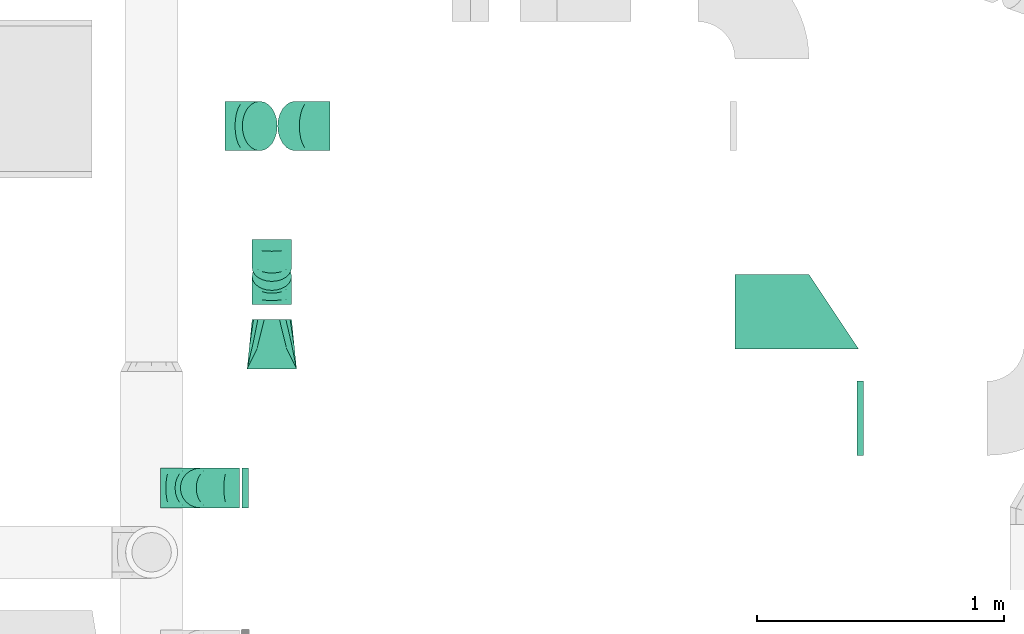
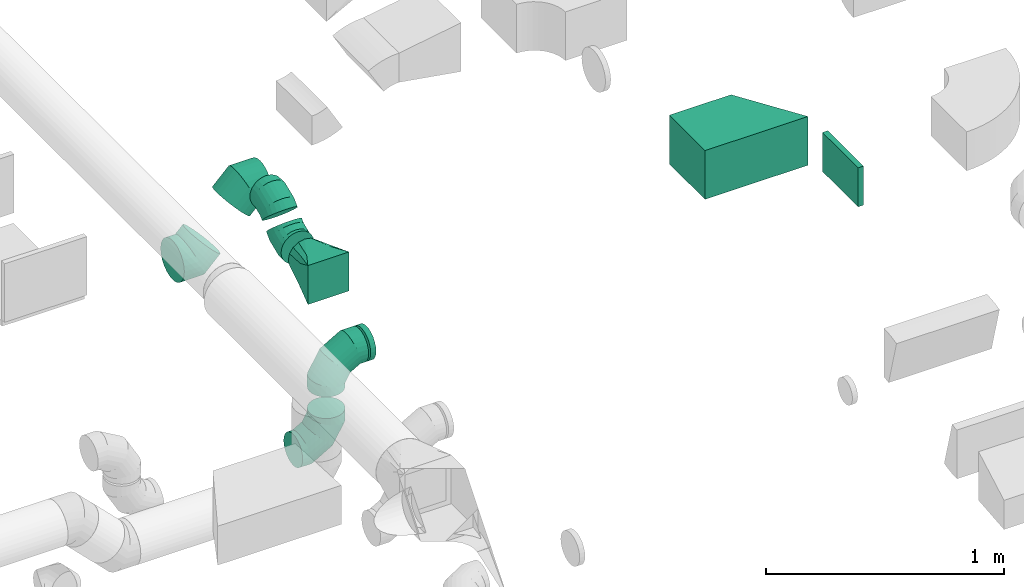
# One storey, part 45 of 62: 10 flow fittings.
"""IFC2X3 building model written with IfcOpenShell, lengths in millimetres."""

from ifc_helpers import new_model, entity, si_unit, converted_unit, derived_unit, direction, frame, origin, origin_2d_with_axis, place, context, subcontext, project, spatial, polyline, rectangle, outline, extrude, faceted_brep, source, transform, mapped, material, type_object, type_shapes, element, save


model = new_model("IFC2X3")

# Units and contexts
model_context = context("Model", 3, precision=0.01, world=origin(), true_north=direction((6.12303176911189e-17, 1.0)))
body_context = subcontext(model_context, "Body", "Model", "MODEL_VIEW")
ifc_project = project(units=[si_unit("LENGTHUNIT", "METRE", prefix="MILLI"), si_unit("AREAUNIT", "SQUARE_METRE"), si_unit("VOLUMEUNIT", "CUBIC_METRE"), converted_unit("PLANEANGLEUNIT", "DEGREE", entity("IfcRatioMeasure", 0.0174532925199433), si_unit("PLANEANGLEUNIT", "RADIAN"), dimensions=[0, 0, 0, 0, 0, 0, 0]), si_unit("MASSUNIT", "GRAM", prefix="KILO"), derived_unit("MASSDENSITYUNIT", [(si_unit("MASSUNIT", "GRAM", prefix="KILO"), 1), (si_unit("LENGTHUNIT", "METRE"), -3)]), derived_unit("MOMENTOFINERTIAUNIT", [(si_unit("LENGTHUNIT", "METRE"), 4)]), si_unit("TIMEUNIT", "SECOND"), si_unit("FREQUENCYUNIT", "HERTZ"), si_unit("THERMODYNAMICTEMPERATUREUNIT", "DEGREE_CELSIUS"), derived_unit("THERMALTRANSMITTANCEUNIT", [(si_unit("MASSUNIT", "GRAM", prefix="KILO"), 1), (si_unit("THERMODYNAMICTEMPERATUREUNIT", "KELVIN"), -1), (si_unit("TIMEUNIT", "SECOND"), -3)]), derived_unit("VOLUMETRICFLOWRATEUNIT", [(si_unit("LENGTHUNIT", "METRE"), 3), (si_unit("TIMEUNIT", "SECOND"), -1)]), derived_unit("MASSFLOWRATEUNIT", [(si_unit("MASSUNIT", "GRAM", prefix="KILO"), 1), (si_unit("TIMEUNIT", "SECOND"), -1)]), derived_unit("ROTATIONALFREQUENCYUNIT", [(si_unit("TIMEUNIT", "SECOND"), -1)]), si_unit("ELECTRICCURRENTUNIT", "AMPERE"), si_unit("ELECTRICVOLTAGEUNIT", "VOLT"), si_unit("POWERUNIT", "WATT"), si_unit("FORCEUNIT", "NEWTON", prefix="KILO"), si_unit("ILLUMINANCEUNIT", "LUX"), si_unit("LUMINOUSFLUXUNIT", "LUMEN"), si_unit("LUMINOUSINTENSITYUNIT", "CANDELA"), derived_unit("USERDEFINED", [(si_unit("MASSUNIT", "GRAM", prefix="KILO"), -1), (si_unit("LENGTHUNIT", "METRE"), -2), (si_unit("TIMEUNIT", "SECOND"), 3), (si_unit("LUMINOUSFLUXUNIT", "LUMEN"), 1)]), derived_unit("LINEARVELOCITYUNIT", [(si_unit("LENGTHUNIT", "METRE"), 1), (si_unit("TIMEUNIT", "SECOND"), -1)]), si_unit("PRESSUREUNIT", "PASCAL"), derived_unit("USERDEFINED", [(si_unit("LENGTHUNIT", "METRE"), -2), (si_unit("MASSUNIT", "GRAM", prefix="KILO"), 1), (si_unit("TIMEUNIT", "SECOND"), -2)]), derived_unit("LINEARFORCEUNIT", [(si_unit("MASSUNIT", "GRAM", prefix="KILO"), 1), (si_unit("LENGTHUNIT", "METRE"), 1), (si_unit("TIMEUNIT", "SECOND"), -2), (si_unit("LENGTHUNIT", "METRE"), -1)]), derived_unit("PLANARFORCEUNIT", [(si_unit("MASSUNIT", "GRAM", prefix="KILO"), 1), (si_unit("LENGTHUNIT", "METRE"), 1), (si_unit("TIMEUNIT", "SECOND"), -2), (si_unit("LENGTHUNIT", "METRE"), -2)])], contexts=[model_context])

# Site, building, storey
site_placement = place(None, origin())
site = spatial("IfcSite", under=ifc_project, at=site_placement, CompositionType="ELEMENT")
building_placement = place(site_placement, origin())
building = spatial("IfcBuilding", under=site, at=building_placement, CompositionType="ELEMENT")
storey_placement = place(building_placement, frame((0.0, 0.0, 24000.0)))
storey = spatial("IfcBuildingStorey", under=building, at=storey_placement, CompositionType="ELEMENT", Elevation=24000.0)

# Flow fittings
ifc_material = material()
duct_fitting_type_1 = type_object("IfcDuctFittingType", PredefinedType="NOTDEFINED", material=ifc_material)
shared_shape_1 = source(origin(), body_context, "Body", "SweptSolid", [
    extrude(rectangle(XDim=26.096000000001, YDim=300.0, at=origin_2d_with_axis()), frame((6.95, 0.0, -100.0)), (0.0, 0.0, 1.0), 200.0),
])
type_shapes(duct_fitting_type_1, [shared_shape_1])
flow_fitting_1_placement = place(storey_placement, frame((53615.82, 12852.02, 3400.0), z_axis=(0.0, 0.0, -1.0), x_axis=(1.0, 0.0, 0.0)))
element("IfcFlowFitting", 1, at=flow_fitting_1_placement, inside=storey, type_object=duct_fitting_type_1, material=ifc_material, context=body_context, shape_type="MappedRepresentation", body=[
    mapped(shared_shape_1, transform((0.0, 0.0, 0.0), scale=1.0)),
])
duct_fitting_type_2 = type_object("IfcDuctFittingType", PredefinedType="NOTDEFINED", material=ifc_material)
shared_shape_2 = source(origin(), body_context, "Body", "SweptSolid", [
    extrude(outline(polyline([(-291.22, -166.41), (69.34, -166.41), (235.75, 83.21), (-13.87, 249.62), (-291.22, -166.41)])), frame((150.0, 50.0, -125.0), z_axis=(0.0, 0.0, 1.0), x_axis=(0.832050294337984, 0.554700196225018, 0.0)), (0.0, 0.0, 1.0), 250.0),
])
type_shapes(duct_fitting_type_2, [shared_shape_2])
flow_fitting_2_placement = place(storey_placement, frame((53365.82, 13133.04, 3375.0), z_axis=(0.0, 0.0, 1.0), x_axis=(0.0, 1.0, 0.0)))
element("IfcFlowFitting", 2, at=flow_fitting_2_placement, inside=storey, type_object=duct_fitting_type_2, material=ifc_material, context=body_context, shape_type="MappedRepresentation", body=[
    mapped(shared_shape_2, transform((0.0, 0.0, 0.0), scale=1.0)),
])
duct_fitting_type_3 = type_object("IfcDuctFittingType", PredefinedType="NOTDEFINED", material=ifc_material)
shared_shape_3 = source(origin(), body_context, "Body", "Brep", [
    faceted_brep([(-160.0, 0.0, -80.0), (-160.0, -20.71, -77.27), (-160.0, -40.0, -69.28), (-160.0, -56.57, -56.57), (-160.0, -69.28, -40.0), (-160.0, -77.27, -20.71), (-160.0, -80.0, 0.0), (-160.0, -77.27, 20.71), (-160.0, -69.28, 40.0), (-160.0, -56.57, 56.57), (-160.0, -40.0, 69.28), (-160.0, -20.71, 77.27), (-160.0, 0.0, 80.0), (-160.0, 20.71, 77.27), (-160.0, 40.0, 69.28), (-160.0, 56.57, 56.57), (-160.0, 69.28, 40.0), (-160.0, 77.27, 20.71), (-160.0, 80.0, 0.0), (-160.0, 77.27, -20.71), (-160.0, 69.28, -40.0), (-160.0, 56.57, -56.57), (-160.0, 40.0, -69.28), (-160.0, 20.71, -77.27), (-122.68, 20.71, 77.27), (-127.85, 40.0, 69.28), (-117.13, 0.0, 80.0), (-132.29, 56.57, 56.57), (-137.83, 77.27, 20.71), (-138.56, 80.0, 0.0), (-135.69, 69.28, 40.0), (-135.69, 69.28, -40.0), (-132.29, 56.57, -56.57), (-137.83, 77.27, -20.71), (-122.68, 20.71, -77.27), (-117.13, 0.0, -80.0), (-127.85, 40.0, -69.28), (-111.58, -20.71, -77.27), (-106.41, -40.0, -69.28), (-101.97, -56.57, -56.57), (-98.56, -69.28, -40.0), (-96.42, -77.27, -20.71), (-95.69, -80.0, 0.0), (-96.42, -77.27, 20.71), (-98.56, -69.28, 40.0), (-101.97, -56.57, 56.57), (-106.41, -40.0, 69.28), (-111.58, -20.71, 77.27), (-58.03, 58.03, 77.27), (-72.15, 72.15, 69.28), (-42.87, 42.87, 80.0), (-84.28, 84.28, 56.57), (-93.59, 93.59, 40.0), (-99.44, 99.44, 20.71), (-101.44, 101.44, 0.0), (-99.44, 99.44, -20.71), (-93.59, 93.59, -40.0), (-84.28, 84.28, -56.57), (-58.03, 58.03, -77.27), (-42.87, 42.87, -80.0), (-72.15, 72.15, -69.28), (-27.71, 27.71, -77.27), (-13.59, 13.59, -69.28), (-1.46, 1.46, -56.57), (7.85, -7.85, -40.0), (13.7, -13.7, -20.71), (15.69, -15.69, 0.0), (13.7, -13.7, 20.71), (7.85, -7.85, 40.0), (-1.46, 1.46, 56.57), (-13.59, 13.59, 69.28), (-27.71, 27.71, 77.27), (-20.71, 122.68, 77.27), (-40.0, 127.85, 69.28), (0.0, 117.13, 80.0), (-56.57, 132.29, 56.57), (-69.28, 135.69, 40.0), (-77.27, 137.83, 20.71), (-80.0, 138.56, 0.0), (-77.27, 137.83, -20.71), (-69.28, 135.69, -40.0), (-56.57, 132.29, -56.57), (-20.71, 122.68, -77.27), (0.0, 117.13, -80.0), (-40.0, 127.85, -69.28), (20.71, 111.58, -77.27), (40.0, 106.41, -69.28), (56.57, 101.97, -56.57), (69.28, 98.56, -40.0), (77.27, 96.42, -20.71), (80.0, 95.69, 0.0), (77.27, 96.42, 20.71), (69.28, 98.56, 40.0), (56.57, 101.97, 56.57), (40.0, 106.41, 69.28), (20.71, 111.58, 77.27), (-20.71, 160.0, -77.27), (-40.0, 160.0, -69.28), (-56.57, 160.0, -56.57), (-69.28, 160.0, -40.0), (-77.27, 160.0, -20.71), (-80.0, 160.0, 0.0), (-77.27, 160.0, 20.71), (-69.28, 160.0, 40.0), (-56.57, 160.0, 56.57), (-40.0, 160.0, 69.28), (-20.71, 160.0, 77.27), (0.0, 160.0, 80.0), (20.71, 160.0, 77.27), (40.0, 160.0, 69.28), (56.57, 160.0, 56.57), (69.28, 160.0, 40.0), (77.27, 160.0, 20.71), (80.0, 160.0, 0.0), (77.27, 160.0, -20.71), (69.28, 160.0, -40.0), (56.57, 160.0, -56.57), (40.0, 160.0, -69.28), (20.71, 160.0, -77.27), (0.0, 160.0, -80.0)], [[[0, 1, 2, 3, 4, 5, 6, 7, 8, 9, 10, 11, 12, 13, 14, 15, 16, 17, 18, 19, 20, 21, 22, 23]], [[24, 25, 14, 13]], [[26, 24, 13, 12]], [[14, 25, 27, 15]], [[28, 29, 18, 17]], [[30, 28, 17, 16]], [[15, 27, 30, 16]], [[20, 31, 32, 21]], [[33, 31, 20, 19]], [[18, 29, 33, 19]], [[34, 35, 0, 23]], [[36, 34, 23, 22]], [[32, 36, 22, 21]], [[1, 0, 35, 37]], [[2, 1, 37, 38]], [[3, 2, 38, 39]], [[5, 4, 40, 41]], [[6, 5, 41, 42]], [[39, 40, 4, 3]], [[6, 42, 43, 7]], [[7, 43, 44, 8]], [[8, 44, 45, 9]], [[9, 45, 46, 10]], [[10, 46, 47, 11]], [[26, 12, 11, 47]], [[48, 49, 25, 24]], [[50, 48, 24, 26]], [[27, 25, 49, 51]], [[52, 53, 28, 30]], [[51, 52, 30, 27]], [[29, 28, 53, 54]], [[55, 56, 31, 33]], [[54, 55, 33, 29]], [[32, 31, 56, 57]], [[58, 59, 35, 34]], [[60, 58, 34, 36]], [[57, 60, 36, 32]], [[37, 35, 59, 61]], [[38, 37, 61, 62]], [[39, 38, 62, 63]], [[41, 40, 64, 65]], [[42, 41, 65, 66]], [[63, 64, 40, 39]], [[43, 42, 66, 67]], [[44, 43, 67, 68]], [[68, 69, 45, 44]], [[46, 45, 69, 70]], [[47, 46, 70, 71]], [[26, 47, 71, 50]], [[72, 73, 49, 48]], [[74, 72, 48, 50]], [[51, 49, 73, 75]], [[76, 77, 53, 52]], [[75, 76, 52, 51]], [[54, 53, 77, 78]], [[79, 80, 56, 55]], [[78, 79, 55, 54]], [[57, 56, 80, 81]], [[82, 83, 59, 58]], [[84, 82, 58, 60]], [[81, 84, 60, 57]], [[61, 59, 83, 85]], [[62, 61, 85, 86]], [[63, 62, 86, 87]], [[65, 64, 88, 89]], [[66, 65, 89, 90]], [[87, 88, 64, 63]], [[67, 66, 90, 91]], [[68, 67, 91, 92]], [[92, 93, 69, 68]], [[70, 69, 93, 94]], [[71, 70, 94, 95]], [[50, 71, 95, 74]], [[96, 97, 98, 99, 100, 101, 102, 103, 104, 105, 106, 107, 108, 109, 110, 111, 112, 113, 114, 115, 116, 117, 118, 119]], [[72, 74, 107, 106]], [[73, 72, 106, 105]], [[75, 73, 105, 104]], [[77, 76, 103, 102]], [[78, 77, 102, 101]], [[75, 104, 103, 76]], [[78, 101, 100, 79]], [[79, 100, 99, 80]], [[80, 99, 98, 81]], [[84, 97, 96, 82]], [[82, 96, 119, 83]], [[84, 81, 98, 97]], [[118, 117, 86, 85]], [[119, 118, 85, 83]], [[116, 87, 86, 117]], [[88, 115, 114, 89]], [[89, 114, 113, 90]], [[115, 88, 87, 116]], [[112, 111, 92, 91]], [[113, 112, 91, 90]], [[111, 110, 93, 92]], [[95, 94, 109, 108]], [[74, 95, 108, 107]], [[110, 109, 94, 93]]]),
])
type_shapes(duct_fitting_type_3, [shared_shape_3])
for number, where, z_axis, x_axis in (
    (3, (50952.88, 12570.09, 3120.0), (0.0, -1.0, 0.0), (1.0, 0.0, 0.0)),
    (4, (50952.88, 12570.09, 3550.0), (0.0, 1.0, 0.0), (0.0, 0.0, 1.0)),
):
    element("IfcFlowFitting", number, at=place(storey_placement, frame(where, z_axis=z_axis, x_axis=x_axis)), inside=storey, type_object=duct_fitting_type_3, material=ifc_material, context=body_context, shape_type="MappedRepresentation", body=[
        mapped(shared_shape_3, transform((0.0, 0.0, 0.0), scale=1.0)),
    ])
duct_fitting_type_4 = type_object("IfcDuctFittingType", PredefinedType="NOTDEFINED", material=ifc_material)
shared_shape_4 = source(origin(), body_context, "Body", "Brep", [
    faceted_brep([(-82.84, 0.0, -100.0), (-82.84, -25.88, -96.59), (-82.84, -50.0, -86.6), (-82.84, -70.71, -70.71), (-82.84, -86.6, -50.0), (-82.84, -96.59, -25.88), (-82.84, -100.0, 0.0), (-82.84, -96.59, 25.88), (-82.84, -86.6, 50.0), (-82.84, -70.71, 70.71), (-82.84, -50.0, 86.6), (-82.84, -25.88, 96.59), (-82.84, 0.0, 100.0), (-82.84, 25.88, 96.59), (-82.84, 50.0, 86.6), (-82.84, 70.71, 70.71), (-82.84, 86.6, 50.0), (-82.84, 96.59, 25.88), (-82.84, 100.0, 0.0), (-82.84, 96.59, -25.88), (-82.84, 86.6, -50.0), (-82.84, 70.71, -70.71), (-82.84, 50.0, -86.6), (-82.84, 25.88, -96.59), (-10.72, 25.88, 96.59), (-20.71, 50.0, 86.6), (0.0, 0.0, 100.0), (-29.29, 70.71, 70.71), (-35.87, 86.6, 50.0), (-40.01, 96.59, 25.88), (-41.42, 100.0, 0.0), (-40.01, 96.59, -25.88), (-35.87, 86.6, -50.0), (-29.29, 70.71, -70.71), (-10.72, 25.88, -96.59), (0.0, 0.0, -100.0), (-20.71, 50.0, -86.6), (10.72, -25.88, -96.59), (20.71, -50.0, -86.6), (29.29, -70.71, -70.71), (35.87, -86.6, -50.0), (40.01, -96.59, -25.88), (41.42, -100.0, 0.0), (40.01, -96.59, 25.88), (35.87, -86.6, 50.0), (29.29, -70.71, 70.71), (20.71, -50.0, 86.6), (10.72, -25.88, 96.59), (58.58, 58.58, 100.0), (40.28, 76.88, 96.59), (23.22, 93.93, 86.6), (8.58, 108.58, 70.71), (-2.66, 119.82, 50.0), (-9.72, 126.88, 25.88), (-12.13, 129.29, 0.0), (-9.72, 126.88, -25.88), (-2.66, 119.82, -50.0), (8.58, 108.58, -70.71), (23.22, 93.93, -86.6), (40.28, 76.88, -96.59), (58.58, 58.58, -100.0), (76.88, 40.28, -96.59), (93.93, 23.22, -86.6), (108.58, 8.58, -70.71), (119.82, -2.66, -50.0), (126.88, -9.72, -25.88), (129.29, -12.13, 0.0), (126.88, -9.72, 25.88), (119.82, -2.66, 50.0), (108.58, 8.58, 70.71), (93.93, 23.22, 86.6), (76.88, 40.28, 96.59)], [[[0, 1, 2, 3, 4, 5, 6, 7, 8, 9, 10, 11, 12, 13, 14, 15, 16, 17, 18, 19, 20, 21, 22, 23]], [[24, 25, 14, 13]], [[26, 24, 13, 12]], [[14, 25, 27, 15]], [[28, 29, 17, 16]], [[28, 16, 15, 27]], [[30, 18, 17, 29]], [[31, 32, 20, 19]], [[30, 31, 19, 18]], [[32, 33, 21, 20]], [[34, 35, 0, 23]], [[36, 34, 23, 22]], [[33, 36, 22, 21]], [[1, 0, 35, 37]], [[2, 1, 37, 38]], [[38, 39, 3, 2]], [[5, 4, 40, 41]], [[6, 5, 41, 42]], [[39, 40, 4, 3]], [[6, 42, 43, 7]], [[7, 43, 44, 8]], [[8, 44, 45, 9]], [[9, 45, 46, 10]], [[10, 46, 47, 11]], [[26, 12, 11, 47]], [[24, 26, 48, 49]], [[25, 24, 49, 50]], [[27, 25, 50, 51]], [[29, 28, 52, 53]], [[30, 29, 53, 54]], [[51, 52, 28, 27]], [[30, 54, 55, 31]], [[31, 55, 56, 32]], [[57, 33, 32, 56]], [[36, 58, 59, 34]], [[34, 59, 60, 35]], [[58, 36, 33, 57]], [[35, 60, 61, 37]], [[37, 61, 62, 38]], [[63, 39, 38, 62]], [[40, 64, 65, 41]], [[41, 65, 66, 42]], [[64, 40, 39, 63]], [[43, 42, 66, 67]], [[44, 43, 67, 68]], [[68, 69, 45, 44]], [[47, 46, 70, 71]], [[26, 47, 71, 48]], [[69, 70, 46, 45]], [[59, 58, 57, 56, 55, 54, 53, 52, 51, 50, 49, 48, 71, 70, 69, 68, 67, 66, 65, 64, 63, 62, 61, 60]]]),
])
type_shapes(duct_fitting_type_4, [shared_shape_4])
for number, where, z_axis, x_axis in (
    (5, (51395.82, 14034.27, 3375.0), (0.0, -1.0, 0.0), (-1.0, 0.0, 0.0)),
    (6, (51135.53, 14034.27, 3114.71), (0.0, 1.0, 0.0), (-0.707106781186499, 0.0, -0.707106781186596)),
):
    element("IfcFlowFitting", number, at=place(storey_placement, frame(where, z_axis=z_axis, x_axis=x_axis)), inside=storey, type_object=duct_fitting_type_4, material=ifc_material, context=body_context, shape_type="MappedRepresentation", body=[
        mapped(shared_shape_4, transform((0.0, 0.0, 0.0), scale=1.0)),
    ])
duct_fitting_type_5 = type_object("IfcDuctFittingType", PredefinedType="NOTDEFINED", material=ifc_material)
shared_shape_5 = source(origin(), body_context, "Body", "Brep", [
    faceted_brep([(20.0, 20.71, -77.27), (20.0, 40.0, -69.28), (20.0, 56.57, -56.57), (20.0, 69.28, -40.0), (20.0, 77.27, -20.71), (20.0, 80.0, 0.0), (20.0, 77.27, 20.71), (20.0, 69.28, 40.0), (20.0, 56.57, 56.57), (20.0, 40.0, 69.28), (20.0, 20.71, 77.27), (20.0, 0.0, 80.0), (20.0, -20.71, 77.27), (20.0, -40.0, 69.28), (20.0, -56.57, 56.57), (20.0, -69.28, 40.0), (20.0, -77.27, 20.71), (20.0, -80.0, 0.0), (20.0, -77.27, -20.71), (20.0, -69.28, -40.0), (20.0, -56.57, -56.57), (20.0, -40.0, -69.28), (20.0, -20.71, -77.27), (20.0, 0.0, -80.0), (0.0, 0.0, 80.0), (0.0, 20.71, 77.27), (-6.1, 20.71, 77.27), (-6.1, 0.0, 80.0), (0.0, 40.0, 69.28), (-6.1, 40.0, 69.28), (0.0, 56.57, 56.57), (-6.1, 56.57, 56.57), (0.0, 69.28, 40.0), (0.0, 77.27, 20.71), (-6.1, 77.27, 20.71), (-6.1, 69.28, 40.0), (0.0, 80.0, 0.0), (-6.1, 80.0, 0.0), (0.0, 77.27, -20.71), (-6.1, 77.27, -20.71), (0.0, 69.28, -40.0), (-6.1, 69.28, -40.0), (0.0, 56.57, -56.57), (-6.1, 56.57, -56.57), (0.0, 40.0, -69.28), (0.0, 20.71, -77.27), (-6.1, 20.71, -77.27), (-6.1, 40.0, -69.28), (0.0, 0.0, -80.0), (-6.1, 0.0, -80.0), (0.0, -20.71, -77.27), (-6.1, -20.71, -77.27), (0.0, -40.0, -69.28), (-6.1, -40.0, -69.28), (0.0, -56.57, -56.57), (-6.1, -56.57, -56.57), (0.0, -69.28, -40.0), (0.0, -77.27, -20.71), (-6.1, -77.27, -20.71), (-6.1, -69.28, -40.0), (0.0, -80.0, 0.0), (-6.1, -80.0, 0.0), (0.0, -77.27, 20.71), (-6.1, -77.27, 20.71), (0.0, -69.28, 40.0), (-6.1, -69.28, 40.0), (0.0, -56.57, 56.57), (-6.1, -56.57, 56.57), (0.0, -40.0, 69.28), (0.0, -20.71, 77.27), (-6.1, -20.71, 77.27), (-6.1, -40.0, 69.28)], [[[0, 1, 2, 3, 4, 5, 6, 7, 8, 9, 10, 11, 12, 13, 14, 15, 16, 17, 18, 19, 20, 21, 22, 23]], [[24, 11, 10, 25, 26, 27]], [[25, 10, 9, 28, 29, 26]], [[28, 9, 8, 30, 31, 29]], [[32, 7, 6, 33, 34, 35]], [[33, 6, 5, 36, 37, 34]], [[30, 8, 7, 32, 35, 31]], [[36, 5, 4, 38, 39, 37]], [[38, 4, 3, 40, 41, 39]], [[40, 3, 2, 42, 43, 41]], [[44, 1, 0, 45, 46, 47]], [[45, 0, 23, 48, 49, 46]], [[42, 2, 1, 44, 47, 43]], [[48, 23, 22, 50, 51, 49]], [[50, 22, 21, 52, 53, 51]], [[52, 21, 20, 54, 55, 53]], [[56, 19, 18, 57, 58, 59]], [[57, 18, 17, 60, 61, 58]], [[54, 20, 19, 56, 59, 55]], [[60, 17, 16, 62, 63, 61]], [[62, 16, 15, 64, 65, 63]], [[64, 15, 14, 66, 67, 65]], [[68, 13, 12, 69, 70, 71]], [[69, 12, 11, 24, 27, 70]], [[66, 14, 13, 68, 71, 67]], [[49, 51, 53, 55, 59, 58, 61, 63, 65, 67, 71, 70, 27, 26, 29, 31, 35, 34, 37, 39, 41, 43, 47, 46]]]),
])
type_shapes(duct_fitting_type_5, [shared_shape_5])
flow_fitting_3_placement = place(storey_placement, frame((51142.9, 12570.09, 3550.0), z_axis=(0.0, 0.0, -1.0), x_axis=(-1.0, 0.0, 0.0)))
element("IfcFlowFitting", 7, at=flow_fitting_3_placement, inside=storey, type_object=duct_fitting_type_5, material=ifc_material, context=body_context, shape_type="MappedRepresentation", body=[
    mapped(shared_shape_5, transform((0.0, 0.0, 0.0), scale=1.0)),
])
duct_fitting_type_6 = type_object("IfcDuctFittingType", PredefinedType="NOTDEFINED", material=ifc_material)
shared_shape_6 = source(origin(), body_context, "Body", "Brep", [
    faceted_brep([(200.0, 30.61, 73.91), (200.0, 22.87, 75.45), (200.0, 15.12, 76.99), (200.0, 11.34, 77.74), (200.0, 7.56, 78.5), (200.0, 0.0, 80.0), (200.0, -7.56, 78.5), (200.0, -15.12, 76.99), (200.0, -18.99, 76.22), (200.0, -22.87, 75.45), (200.0, -30.61, 73.91), (200.0, -37.1, 69.57), (200.0, -43.59, 65.24), (200.0, -50.08, 60.9), (200.0, -56.57, 56.57), (200.0, -60.9, 50.08), (200.0, -65.24, 43.59), (200.0, -69.57, 37.1), (200.0, -73.91, 30.61), (200.0, -75.45, 22.87), (200.0, -76.99, 15.12), (200.0, -77.74, 11.34), (200.0, -78.5, 7.56), (200.0, -80.0, 0.0), (200.0, -78.5, -7.56), (200.0, -76.99, -15.12), (200.0, -76.22, -18.99), (200.0, -75.45, -22.87), (200.0, -73.91, -30.61), (200.0, -69.57, -37.1), (200.0, -65.24, -43.59), (200.0, -60.9, -50.08), (200.0, -56.57, -56.57), (200.0, -50.08, -60.9), (200.0, -43.59, -65.24), (200.0, -37.1, -69.57), (200.0, -30.61, -73.91), (200.0, -22.87, -75.45), (200.0, -15.12, -76.99), (200.0, -11.34, -77.74), (200.0, -7.56, -78.5), (200.0, 0.0, -80.0), (200.0, 7.56, -78.5), (200.0, 15.12, -76.99), (200.0, 18.99, -76.22), (200.0, 22.87, -75.45), (200.0, 30.61, -73.91), (200.0, 37.1, -69.57), (200.0, 43.59, -65.24), (200.0, 50.08, -60.9), (200.0, 56.57, -56.57), (200.0, 60.9, -50.08), (200.0, 65.24, -43.59), (200.0, 69.57, -37.1), (200.0, 73.91, -30.61), (200.0, 75.45, -22.87), (200.0, 76.99, -15.12), (200.0, 77.74, -11.34), (200.0, 78.5, -7.56), (200.0, 80.0, 0.0), (200.0, 78.5, 7.56), (200.0, 76.99, 15.12), (200.0, 76.22, 18.99), (200.0, 75.45, 22.87), (200.0, 73.91, 30.61), (200.0, 69.57, 37.1), (200.0, 65.24, 43.59), (200.0, 60.9, 50.08), (200.0, 56.57, 56.57), (200.0, 50.08, 60.9), (200.0, 43.59, 65.24), (200.0, 37.1, 69.57), (0.0, -100.0, 100.0), (0.0, 100.0, 100.0), (0.0, 100.0, -100.0), (0.0, -100.0, -100.0), (52.06, -73.97, 94.79), (78.09, -60.96, 92.19), (176.03, -11.99, 82.4), (152.06, -23.97, 84.79), (128.09, -35.96, 87.19), (104.11, -47.94, 89.59), (100.0, -79.94, 76.52), (78.09, -92.19, 60.96), (104.11, -89.59, 47.94), (128.09, -87.19, 35.96), (152.06, -84.79, 23.97), (164.04, -83.6, 17.98), (176.03, -82.4, 11.99), (26.03, -97.4, 86.99), (52.06, -94.79, 73.97), (26.03, -86.99, 97.4), (26.03, -97.4, -86.99), (52.06, -94.79, -73.97), (78.09, -92.19, -60.96), (104.11, -89.59, -47.94), (128.09, -87.19, -35.96), (152.06, -84.79, -23.97), (176.03, -82.4, -11.99), (100.0, -76.52, -79.94), (78.09, -60.96, -92.19), (104.11, -47.94, -89.59), (128.09, -35.96, -87.19), (152.06, -23.97, -84.79), (164.04, -17.98, -83.6), (176.03, -11.99, -82.4), (26.03, -86.99, -97.4), (52.06, -73.97, -94.79), (26.03, 86.99, -97.4), (52.06, 73.97, -94.79), (78.09, 60.96, -92.19), (104.11, 47.94, -89.59), (128.09, 35.96, -87.19), (152.06, 23.97, -84.79), (176.03, 11.99, -82.4), (100.0, 79.94, -76.52), (78.09, 92.19, -60.96), (104.11, 89.59, -47.94), (128.09, 87.19, -35.96), (152.06, 84.79, -23.97), (164.04, 83.6, -17.98), (176.03, 82.4, -11.99), (26.03, 97.4, -86.99), (52.06, 94.79, -73.97), (26.03, 97.4, 86.99), (52.06, 94.79, 73.97), (78.09, 92.19, 60.96), (104.11, 89.59, 47.94), (128.09, 87.19, 35.96), (152.06, 84.79, 23.97), (176.03, 82.4, 11.99), (100.0, 76.52, 79.94), (78.09, 60.96, 92.19), (104.11, 47.94, 89.59), (128.09, 35.96, 87.19), (152.06, 23.97, 84.79), (164.04, 17.98, 83.6), (176.03, 11.99, 82.4), (26.03, 86.99, 97.4), (52.06, 73.97, 94.79)], [[[0, 1, 2, 3, 4, 5, 6, 7, 8, 9, 10, 11, 12, 13, 14, 15, 16, 17, 18, 19, 20, 21, 22, 23, 24, 25, 26, 27, 28, 29, 30, 31, 32, 33, 34, 35, 36, 37, 38, 39, 40, 41, 42, 43, 44, 45, 46, 47, 48, 49, 50, 51, 52, 53, 54, 55, 56, 57, 58, 59, 60, 61, 62, 63, 64, 65, 66, 67, 68, 69, 70, 71]], [[72, 73, 74, 75]], [[76, 12, 77]], [[12, 11, 10, 77]], [[78, 79, 80, 81, 77, 10, 9, 8, 7, 6, 5]], [[13, 82, 14]], [[20, 19, 18, 83, 84, 85, 86, 87, 88, 23, 22, 21]], [[82, 72, 89]], [[82, 15, 14]], [[83, 16, 90]], [[91, 72, 82]], [[18, 17, 16, 83]], [[90, 16, 15]], [[15, 82, 89]], [[90, 15, 89]], [[76, 13, 12]], [[13, 76, 91]], [[82, 13, 91]], [[88, 87, 86, 85, 84, 83, 90, 89, 72, 75, 92, 93, 94, 95, 96, 97, 98, 23]], [[93, 30, 94]], [[30, 29, 28, 94]], [[98, 97, 96, 95, 94, 28, 27, 26, 25, 24, 23]], [[31, 99, 32]], [[38, 37, 36, 100, 101, 102, 103, 104, 105, 41, 40, 39]], [[99, 75, 106]], [[99, 33, 32]], [[100, 34, 107]], [[92, 75, 99]], [[36, 35, 34, 100]], [[107, 34, 33]], [[33, 99, 106]], [[107, 33, 106]], [[93, 31, 30]], [[31, 93, 92]], [[99, 31, 92]], [[105, 104, 103, 102, 101, 100, 107, 106, 75, 74, 108, 109, 110, 111, 112, 113, 114, 41]], [[109, 48, 110]], [[48, 47, 46, 110]], [[114, 113, 112, 111, 110, 46, 45, 44, 43, 42, 41]], [[49, 115, 50]], [[56, 55, 54, 116, 117, 118, 119, 120, 121, 59, 58, 57]], [[115, 74, 122]], [[115, 51, 50]], [[116, 52, 123]], [[108, 74, 115]], [[54, 53, 52, 116]], [[123, 52, 51]], [[51, 115, 122]], [[123, 51, 122]], [[109, 49, 48]], [[49, 109, 108]], [[115, 49, 108]], [[74, 73, 124, 125, 126, 127, 128, 129, 130, 59, 121, 120, 119, 118, 117, 116, 123, 122]], [[125, 66, 126]], [[66, 65, 64, 126]], [[130, 129, 128, 127, 126, 64, 63, 62, 61, 60, 59]], [[67, 131, 68]], [[2, 1, 0, 132, 133, 134, 135, 136, 137, 5, 4, 3]], [[131, 73, 138]], [[131, 69, 68]], [[132, 70, 139]], [[124, 73, 131]], [[0, 71, 70, 132]], [[139, 70, 69]], [[69, 131, 138]], [[139, 69, 138]], [[125, 67, 66]], [[67, 125, 124]], [[131, 67, 124]], [[73, 72, 91, 76, 77, 81, 80, 79, 78, 5, 137, 136, 135, 134, 133, 132, 139, 138]]]),
])
type_shapes(duct_fitting_type_6, [shared_shape_6])
flow_fitting_4_placement = place(storey_placement, frame((51242.9, 13052.41, 3550.0), z_axis=(0.0, 0.0, 1.0), x_axis=(0.0, 1.0, 0.0)))
element("IfcFlowFitting", 8, at=flow_fitting_4_placement, inside=storey, type_object=duct_fitting_type_6, material=ifc_material, context=body_context, shape_type="MappedRepresentation", body=[
    mapped(shared_shape_6, transform((0.0, 0.0, 0.0), scale=1.0)),
])
duct_fitting_type_7 = type_object("IfcDuctFittingType", PredefinedType="NOTDEFINED", material=ifc_material)
shared_shape_7 = source(origin(), body_context, "Body", "Brep", [
    faceted_brep([(-66.27, 0.0, -80.0), (-66.27, -20.71, -77.27), (-66.27, -40.0, -69.28), (-66.27, -56.57, -56.57), (-66.27, -69.28, -40.0), (-66.27, -77.27, -20.71), (-66.27, -80.0, 0.0), (-66.27, -77.27, 20.71), (-66.27, -69.28, 40.0), (-66.27, -56.57, 56.57), (-66.27, -40.0, 69.28), (-66.27, -20.71, 77.27), (-66.27, 0.0, 80.0), (-66.27, 20.71, 77.27), (-66.27, 40.0, 69.28), (-66.27, 56.57, 56.57), (-66.27, 69.28, 40.0), (-66.27, 77.27, 20.71), (-66.27, 80.0, 0.0), (-66.27, 77.27, -20.71), (-66.27, 69.28, -40.0), (-66.27, 56.57, -56.57), (-66.27, 40.0, -69.28), (-66.27, 20.71, -77.27), (-38.57, 20.71, 77.27), (-42.4, 40.0, 69.28), (-34.45, 0.0, 80.0), (-45.7, 56.57, 56.57), (-49.82, 77.27, 20.71), (-50.36, 80.0, 0.0), (-48.23, 69.28, 40.0), (-48.23, 69.28, -40.0), (-45.7, 56.57, -56.57), (-49.82, 77.27, -20.71), (-38.57, 20.71, -77.27), (-34.45, 0.0, -80.0), (-42.4, 40.0, -69.28), (-30.33, -20.71, -77.27), (-26.49, -40.0, -69.28), (-23.2, -56.57, -56.57), (-20.67, -69.28, -40.0), (-19.08, -77.27, -20.71), (-18.54, -80.0, 0.0), (-19.08, -77.27, 20.71), (-20.67, -69.28, 40.0), (-23.2, -56.57, 56.57), (-26.49, -40.0, 69.28), (-30.33, -20.71, 77.27), (12.63, 41.91, 77.27), (1.7, 58.27, 69.28), (24.36, 24.36, 80.0), (-7.68, 72.32, 56.57), (-14.89, 83.09, 40.0), (-19.41, 89.87, 20.71), (-20.96, 92.18, 0.0), (-19.41, 89.87, -20.71), (-14.89, 83.09, -40.0), (-7.68, 72.32, -56.57), (12.63, 41.91, -77.27), (24.36, 24.36, -80.0), (1.7, 58.27, -69.28), (36.09, 6.81, -77.27), (47.02, -9.55, -69.28), (56.4, -23.6, -56.57), (63.6, -34.38, -40.0), (68.13, -41.15, -20.71), (69.67, -43.46, 0.0), (68.13, -41.15, 20.71), (63.6, -34.38, 40.0), (56.4, -23.6, 56.57), (47.02, -9.55, 69.28), (36.09, 6.81, 77.27), (46.86, 46.86, 80.0), (32.22, 61.5, 77.27), (18.58, 75.15, 69.28), (6.86, 86.86, 56.57), (-2.13, 95.85, 40.0), (-7.78, 101.5, 20.71), (-9.71, 103.43, 0.0), (-7.78, 101.5, -20.71), (-2.13, 95.85, -40.0), (6.86, 86.86, -56.57), (18.58, 75.15, -69.28), (32.22, 61.5, -77.27), (46.86, 46.86, -80.0), (61.5, 32.22, -77.27), (75.15, 18.58, -69.28), (86.86, 6.86, -56.57), (101.5, -7.78, -20.71), (103.43, -9.71, 0.0), (95.85, -2.13, -40.0), (101.5, -7.78, 20.71), (95.85, -2.13, 40.0), (86.86, 6.86, 56.57), (61.5, 32.22, 77.27), (75.15, 18.58, 69.28)], [[[0, 1, 2, 3, 4, 5, 6, 7, 8, 9, 10, 11, 12, 13, 14, 15, 16, 17, 18, 19, 20, 21, 22, 23]], [[24, 25, 14, 13]], [[26, 24, 13, 12]], [[14, 25, 27, 15]], [[28, 29, 18, 17]], [[30, 28, 17, 16]], [[15, 27, 30, 16]], [[20, 31, 32, 21]], [[33, 31, 20, 19]], [[18, 29, 33, 19]], [[34, 35, 0, 23]], [[36, 34, 23, 22]], [[32, 36, 22, 21]], [[2, 1, 37, 38]], [[3, 2, 38, 39]], [[0, 35, 37, 1]], [[5, 4, 40, 41]], [[6, 5, 41, 42]], [[3, 39, 40, 4]], [[6, 42, 43, 7]], [[7, 43, 44, 8]], [[8, 44, 45, 9]], [[10, 46, 47, 11]], [[11, 47, 26, 12]], [[9, 45, 46, 10]], [[48, 49, 25, 24]], [[50, 48, 24, 26]], [[27, 25, 49, 51]], [[52, 53, 28, 30]], [[51, 52, 30, 27]], [[29, 28, 53, 54]], [[55, 56, 31, 33]], [[54, 55, 33, 29]], [[32, 31, 56, 57]], [[58, 59, 35, 34]], [[60, 58, 34, 36]], [[57, 60, 36, 32]], [[37, 35, 59, 61]], [[38, 37, 61, 62]], [[39, 38, 62, 63]], [[41, 40, 64, 65]], [[42, 41, 65, 66]], [[63, 64, 40, 39]], [[43, 42, 66, 67]], [[44, 43, 67, 68]], [[68, 69, 45, 44]], [[46, 45, 69, 70]], [[47, 46, 70, 71]], [[26, 47, 71, 50]], [[48, 50, 72, 73]], [[49, 48, 73, 74]], [[51, 49, 74, 75]], [[53, 52, 76, 77]], [[54, 53, 77, 78]], [[51, 75, 76, 52]], [[54, 78, 79, 55]], [[55, 79, 80, 56]], [[56, 80, 81, 57]], [[60, 82, 83, 58]], [[58, 83, 84, 59]], [[60, 57, 81, 82]], [[59, 84, 85, 61]], [[61, 85, 86, 62]], [[62, 86, 87, 63]], [[88, 89, 66, 65]], [[90, 88, 65, 64]], [[63, 87, 90, 64]], [[67, 66, 89, 91]], [[68, 67, 91, 92]], [[69, 68, 92, 93]], [[94, 72, 50, 71]], [[95, 94, 71, 70]], [[93, 95, 70, 69]], [[83, 82, 81, 80, 79, 78, 77, 76, 75, 74, 73, 72, 94, 95, 93, 92, 91, 89, 88, 90, 87, 86, 85, 84]]]),
])
type_shapes(duct_fitting_type_7, [shared_shape_7])
for number, where, z_axis, x_axis in (
    (9, (51242.9, 13379.13, 3550.0), (1.0, 0.0, 0.0), (0.0, 1.0, 0.0)),
    (10, (51242.9, 13509.12, 3680.0), (-1.0, 0.0, 0.0), (0.0, 0.707106626710661, 0.7071069356624)),
):
    element("IfcFlowFitting", number, at=place(storey_placement, frame(where, z_axis=z_axis, x_axis=x_axis)), inside=storey, type_object=duct_fitting_type_7, material=ifc_material, context=body_context, shape_type="MappedRepresentation", body=[
        mapped(shared_shape_7, transform((0.0, 0.0, 0.0), scale=1.0)),
    ])

save(model, "model.ifc")
